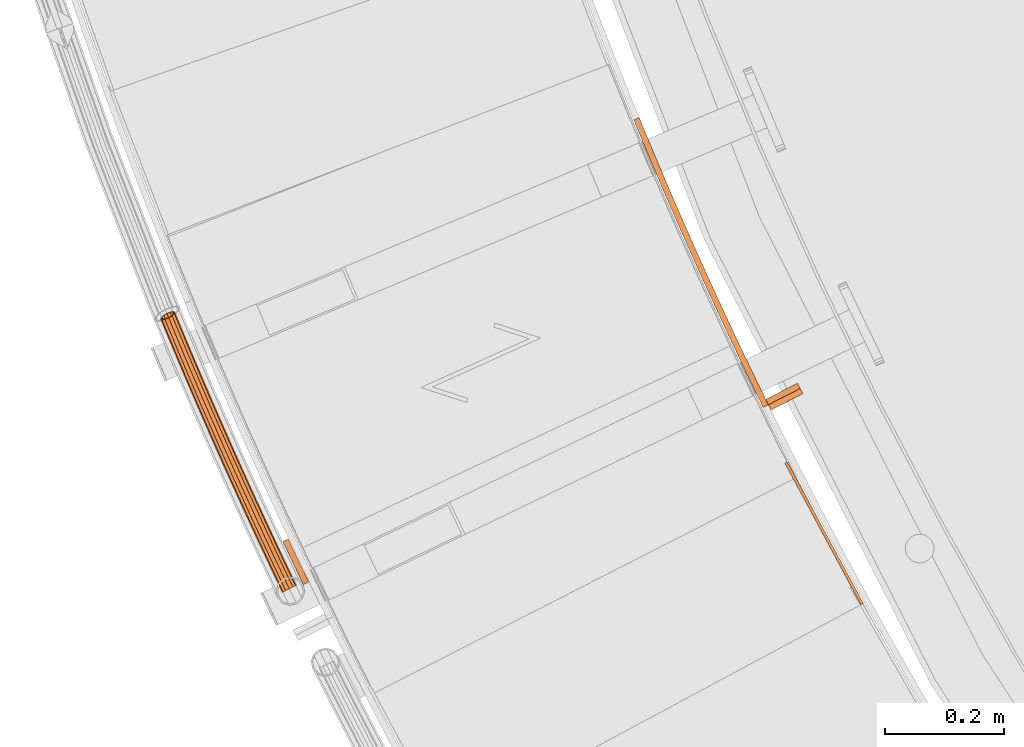
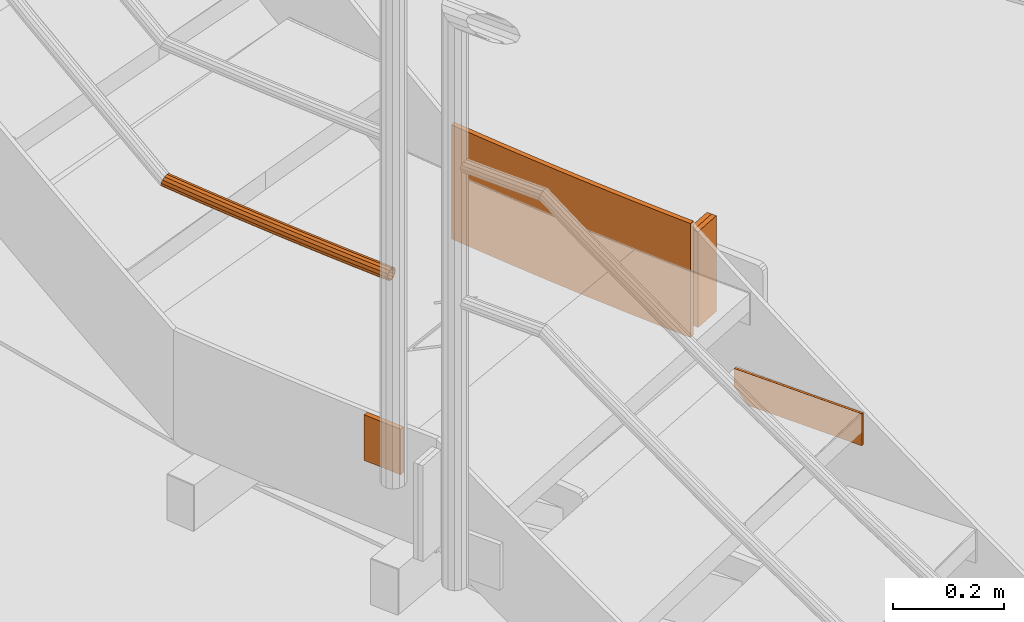
# One storey, part 49 of 126: 6 proxies.
"""IFC2X3 building model written with IfcOpenShell, lengths in millimetres."""

from ifc_helpers import new_model, si_unit, origin, origin_with_axes, place, context, project, spatial, faceted_brep, material, element, save


model = new_model("IFC2X3")

# Units and contexts
context_of_model_1 = context(None, 3, precision=0.1, world=origin())
context_of_model_2 = context(None, 3, precision=0.1, world=origin())
ifc_project = project(units=[si_unit("LENGTHUNIT", "METRE", prefix="MILLI"), si_unit("AREAUNIT", "SQUARE_METRE", prefix="CENTI"), si_unit("VOLUMEUNIT", "CUBIC_METRE", prefix="CENTI"), si_unit("MASSUNIT", "GRAM", prefix="KILO")], contexts=[context_of_model_1, context_of_model_2])

# Site, building, storey
site_placement = place(None, origin_with_axes())
site = spatial("IfcSite", under=ifc_project, at=site_placement, CompositionType="ELEMENT")
building_placement = place(site_placement, origin_with_axes())
building = spatial("IfcBuilding", under=site, at=building_placement, CompositionType="ELEMENT")
storey_placement = place(building_placement, origin_with_axes())
storey = spatial("IfcBuildingStorey", under=building, at=storey_placement, CompositionType="ELEMENT")

# Proxies
ifc_material = material(Name="S235JRG2")
proxy_1_placement = place(storey_placement, origin_with_axes())
element("IfcBuildingElementProxy", 1, at=proxy_1_placement, inside=storey, material=ifc_material, context=context_of_model_2, shape_type="Brep", body=[
    faceted_brep([(972.6505, 4145.1036, 2527.45), (977.0555, 4147.4692, 2527.45), (977.0555, 4147.4692, 2597.45), (972.6505, 4145.1036, 2597.45), (844.9091, 4382.9736, 2597.45), (849.3141, 4385.3392, 2597.45), (849.3141, 4385.3392, 2557.45), (844.9091, 4382.9736, 2557.45), (859.1026, 4356.5436, 2527.45), (863.5076, 4358.9092, 2527.45)], [[[0, 1, 2, 3]], [[4, 5, 6, 7]], [[0, 8, 9, 1]], [[1, 9, 6, 5, 2]], [[2, 5, 4, 3]], [[0, 3, 4, 7, 8]], [[6, 9, 8, 7]]]),
])
proxy_2_placement = place(storey_placement, origin_with_axes())
element("IfcBuildingElementProxy", 2, at=proxy_2_placement, inside=storey, material=ifc_material, context=context_of_model_2, shape_type="Brep", body=[
    faceted_brep([(804.2181, 4485.1622, 2621.25), (813.2023, 4489.5538, 2621.25), (817.3795, 4481.0833, 2621.25), (808.4725, 4476.5352, 2621.25), (813.2023, 4489.5538, 2871.25), (817.3795, 4481.0833, 2871.25), (804.2181, 4485.1622, 2871.25), (808.4725, 4476.5352, 2871.25), (779.8204, 4535.5184, 2621.25), (788.835, 4539.8472, 2621.25), (788.835, 4539.8472, 2871.25), (779.8204, 4535.5184, 2871.25), (755.7747, 4586.0437, 2621.25), (764.8193, 4590.3095, 2621.25), (764.8193, 4590.3095, 2871.25), (755.7747, 4586.0437, 2871.25), (732.0823, 4636.7356, 2621.25), (741.1564, 4640.9382, 2621.25), (741.1564, 4640.9382, 2871.25), (732.0823, 4636.7356, 2871.25), (708.7442, 4687.5917, 2621.25), (717.8475, 4691.7308, 2621.25), (717.8475, 4691.7308, 2871.25), (708.7442, 4687.5917, 2871.25), (685.7617, 4738.6093, 2621.25), (694.8936, 4742.6848, 2621.25), (694.8936, 4742.6848, 2871.25), (685.7617, 4738.6093, 2871.25), (663.1358, 4789.7862, 2621.25), (672.2959, 4793.7978, 2621.25), (672.2959, 4793.7978, 2871.25), (663.1358, 4789.7862, 2871.25), (640.8676, 4841.1197, 2621.25), (650.0555, 4845.0673, 2621.25), (650.0555, 4845.0673, 2871.25), (640.8676, 4841.1197, 2871.25), (618.9583, 4892.6073, 2621.25), (628.1735, 4896.4907, 2621.25), (628.1735, 4896.4907, 2871.25), (618.9583, 4892.6073, 2871.25), (597.4088, 4944.2467, 2621.25), (606.6509, 4948.0657, 2621.25), (606.6509, 4948.0657, 2871.25), (597.4088, 4944.2467, 2871.25), (591.3227, 4959.1223, 2621.25), (600.2601, 4963.686, 2621.25), (600.2601, 4963.686, 2871.25), (591.3227, 4959.1223, 2871.25)], [[[0, 1, 2, 3]], [[1, 4, 5, 2]], [[4, 6, 7, 5]], [[0, 3, 7, 6]], [[0, 8, 9, 1]], [[1, 9, 10, 4]], [[4, 10, 11, 6]], [[6, 11, 8, 0]], [[8, 12, 13, 9]], [[9, 13, 14, 10]], [[10, 14, 15, 11]], [[11, 15, 12, 8]], [[12, 16, 17, 13]], [[13, 17, 18, 14]], [[14, 18, 19, 15]], [[15, 19, 16, 12]], [[16, 20, 21, 17]], [[17, 21, 22, 18]], [[18, 22, 23, 19]], [[19, 23, 20, 16]], [[20, 24, 25, 21]], [[21, 25, 26, 22]], [[22, 26, 27, 23]], [[23, 27, 24, 20]], [[24, 28, 29, 25]], [[25, 29, 30, 26]], [[26, 30, 31, 27]], [[27, 31, 28, 24]], [[28, 32, 33, 29]], [[29, 33, 34, 30]], [[30, 34, 35, 31]], [[31, 35, 32, 28]], [[32, 36, 37, 33]], [[33, 37, 38, 34]], [[34, 38, 39, 35]], [[35, 39, 36, 32]], [[36, 40, 41, 37]], [[37, 41, 42, 38]], [[38, 42, 43, 39]], [[39, 43, 40, 36]], [[40, 44, 45, 41]], [[41, 45, 46, 42]], [[42, 46, 47, 43]], [[40, 43, 47, 44]], [[2, 5, 7, 3]], [[44, 47, 46, 45]]]),
])
proxy_3_placement = place(storey_placement, origin_with_axes())
element("IfcBuildingElementProxy", 3, at=proxy_3_placement, inside=storey, material=ifc_material, context=context_of_model_2, shape_type="Brep", body=[
    faceted_brep([(817.3796, 4481.0831, 2851.25), (812.8319, 4489.9892, 2851.25), (812.8319, 4489.9892, 2641.25), (817.3796, 4481.0831, 2641.25), (866.2685, 4517.2753, 2851.25), (870.8162, 4508.3692, 2851.25), (870.8162, 4508.3692, 2641.25), (866.2685, 4517.2753, 2641.25)], [[[0, 1, 2, 3]], [[4, 5, 6, 7]], [[0, 3, 6, 5]], [[1, 4, 7, 2]], [[0, 5, 4, 1]], [[2, 7, 6, 3]]]),
])
proxy_4_placement = place(storey_placement, origin_with_axes())
element("IfcBuildingElementProxy", 4, at=proxy_4_placement, inside=storey, material=ifc_material, context=context_of_model_2, shape_type="Brep", body=[
    faceted_brep([(821.9273, 4472.177, 2851.25), (817.3796, 4481.0831, 2851.25), (817.3796, 4481.0831, 2641.25), (821.9273, 4472.177, 2641.25), (870.8162, 4508.3692, 2851.25), (875.3639, 4499.4631, 2851.25), (875.3639, 4499.4631, 2641.25), (870.8162, 4508.3692, 2641.25)], [[[0, 1, 2, 3]], [[4, 5, 6, 7]], [[0, 3, 6, 5]], [[1, 4, 7, 2]], [[0, 5, 4, 1]], [[2, 7, 6, 3]]]),
])
proxy_5_placement = place(storey_placement, origin_with_axes())
element("IfcBuildingElementProxy", 5, at=proxy_5_placement, inside=storey, material=ifc_material, context=context_of_model_2, shape_type="Brep", body=[
    faceted_brep([(-4.3297, 4176.1625, 3224.2551), (-2.7039, 4176.9397, 3217.5301), (2.3279, 4166.4608, 3217.5301), (0.7226, 4165.6411, 3224.2551), (1.7377, 4179.063, 3212.607), (6.7137, 4168.7004, 3212.607), (7.805, 4181.9635, 3210.8051), (12.7049, 4171.7596, 3210.8051), (13.8724, 4184.864, 3212.607), (18.696, 4174.8188, 3212.607), (18.314, 4186.9873, 3217.5301), (23.0818, 4177.0583, 3217.5301), (19.9398, 4187.7645, 3224.2551), (24.6872, 4177.878, 3224.2551), (18.314, 4186.9873, 3230.9801), (23.0818, 4177.0583, 3230.9801), (13.8724, 4184.864, 3235.9031), (18.696, 4174.8188, 3235.9031), (7.805, 4181.9635, 3237.7051), (12.7049, 4171.7596, 3237.7051), (1.7377, 4179.063, 3235.9031), (6.7137, 4168.7004, 3235.9031), (-2.7039, 4176.9397, 3230.9801), (2.3279, 4166.4608, 3230.9801), (-2.5253, 4177.0251, 3224.2551), (-1.1413, 4177.6867, 3229.9801), (3.871, 4167.2488, 3229.9801), (2.5044, 4166.5509, 3224.2551), (2.6399, 4179.4943, 3234.1711), (7.6046, 4169.1553, 3234.1711), (7.805, 4181.9635, 3235.7051), (12.7049, 4171.7596, 3235.7051), (12.9702, 4184.4327, 3234.1711), (17.8052, 4174.3639, 3234.1711), (16.7513, 4186.2403, 3229.9801), (21.5388, 4176.2704, 3229.9801), (18.1353, 4186.9019, 3224.2551), (22.9054, 4176.9682, 3224.2551), (16.7513, 4186.2403, 3218.5301), (21.5388, 4176.2704, 3218.5301), (12.9702, 4184.4327, 3214.3391), (17.8052, 4174.3639, 3214.3391), (7.805, 4181.9635, 3212.8051), (12.7049, 4171.7596, 3212.8051), (2.6399, 4179.4943, 3214.3391), (7.6046, 4169.1553, 3214.3391), (-1.1413, 4177.6867, 3218.5301), (3.871, 4167.2488, 3218.5301), (-17.646, 4204.1436, 3224.2551), (-16.0176, 4204.9151, 3217.5301), (-11.5686, 4207.0229, 3212.607), (-5.4911, 4209.9022, 3210.8051), (0.5863, 4212.7815, 3212.607), (5.0353, 4214.8893, 3217.5301), (6.6638, 4215.6608, 3224.2551), (5.0353, 4214.8893, 3230.9801), (0.5863, 4212.7815, 3235.9031), (-5.4911, 4209.9022, 3237.7051), (-11.5686, 4207.0229, 3235.9031), (-16.0176, 4204.9151, 3230.9801), (-15.8386, 4204.9999, 3224.2551), (-14.4523, 4205.6567, 3229.9801), (-10.6649, 4207.4511, 3234.1711), (-5.4911, 4209.9022, 3235.7051), (-0.3174, 4212.3534, 3234.1711), (3.4701, 4214.1477, 3229.9801), (4.8564, 4214.8045, 3224.2551), (3.4701, 4214.1477, 3218.5301), (-0.3174, 4212.3534, 3214.3391), (-5.4911, 4209.9022, 3212.8051), (-10.6649, 4207.4511, 3214.3391), (-14.4523, 4205.6567, 3218.5301), (-30.8646, 4232.171, 3224.2551), (-29.2335, 4232.9369, 3217.5301), (-24.7772, 4235.0291, 3212.607), (-18.6897, 4237.8872, 3210.8051), (-12.6022, 4240.7452, 3212.607), (-8.1459, 4242.8375, 3217.5301), (-6.5148, 4243.6033, 3224.2551), (-8.1459, 4242.8375, 3230.9801), (-12.6022, 4240.7452, 3235.9031), (-18.6897, 4237.8872, 3237.7051), (-24.7772, 4235.0291, 3235.9031), (-29.2335, 4232.9369, 3230.9801), (-29.0542, 4233.021, 3224.2551), (-27.6656, 4233.673, 3229.9801), (-23.872, 4235.4541, 3234.1711), (-18.6897, 4237.8872, 3235.7051), (-13.5074, 4240.3202, 3234.1711), (-9.7137, 4242.1014, 3229.9801), (-8.3252, 4242.7533, 3224.2551), (-9.7137, 4242.1014, 3218.5301), (-13.5074, 4240.3202, 3214.3391), (-18.6897, 4237.8872, 3212.8051), (-23.872, 4235.4541, 3214.3391), (-27.6656, 4233.673, 3218.5301), (-43.9853, 4260.2444, 3224.2551), (-42.3515, 4261.0046, 3217.5301), (-37.8879, 4263.0812, 3212.607), (-31.7905, 4265.918, 3210.8051), (-25.6931, 4268.7548, 3212.607), (-21.2295, 4270.8315, 3217.5301), (-19.5957, 4271.5916, 3224.2551), (-21.2295, 4270.8315, 3230.9801), (-25.6931, 4268.7548, 3235.9031), (-31.7905, 4265.918, 3237.7051), (-37.8879, 4263.0812, 3235.9031), (-42.3515, 4261.0046, 3230.9801), (-42.1719, 4261.0881, 3224.2551), (-40.7811, 4261.7352, 3229.9801), (-36.9812, 4263.5031, 3234.1711), (-31.7905, 4265.918, 3235.7051), (-26.5998, 4268.333, 3234.1711), (-22.7999, 4270.1009, 3229.9801), (-21.409, 4270.7479, 3224.2551), (-22.7999, 4270.1009, 3218.5301), (-26.5998, 4268.333, 3214.3391), (-31.7905, 4265.918, 3212.8051), (-36.9812, 4263.5031, 3214.3391), (-40.7811, 4261.7352, 3218.5301), (-57.0079, 4288.3635, 3224.2551), (-55.3715, 4289.1179, 3217.5301), (-50.9006, 4291.1789, 3212.607), (-44.7934, 4293.9944, 3210.8051), (-38.6861, 4296.8099, 3212.607), (-34.2152, 4298.871, 3217.5301), (-32.5788, 4299.6254, 3224.2551), (-34.2152, 4298.871, 3230.9801), (-38.6861, 4296.8099, 3235.9031), (-44.7934, 4293.9944, 3237.7051), (-50.9006, 4291.1789, 3235.9031), (-55.3715, 4289.1179, 3230.9801), (-55.1916, 4289.2008, 3224.2551), (-53.7985, 4289.843, 3229.9801), (-49.9925, 4291.5976, 3234.1711), (-44.7934, 4293.9944, 3235.7051), (-39.5942, 4296.3913, 3234.1711), (-35.7882, 4298.1459, 3229.9801), (-34.3951, 4298.7881, 3224.2551), (-35.7882, 4298.1459, 3218.5301), (-39.5942, 4296.3913, 3214.3391), (-44.7934, 4293.9944, 3212.8051), (-49.9925, 4291.5976, 3214.3391), (-53.7985, 4289.843, 3218.5301), (-69.9323, 4316.5278, 3224.2551), (-68.2932, 4317.2764, 3217.5301), (-63.8152, 4319.3219, 3212.607), (-57.6981, 4322.1161, 3210.8051), (-51.5811, 4324.9102, 3212.607), (-47.1031, 4326.9557, 3217.5301), (-45.464, 4327.7044, 3224.2551), (-47.1031, 4326.9557, 3230.9801), (-51.5811, 4324.9102, 3235.9031), (-57.6981, 4322.1161, 3237.7051), (-63.8152, 4319.3219, 3235.9031), (-68.2932, 4317.2764, 3230.9801), (-68.1131, 4317.3587, 3224.2551), (-66.7177, 4317.9961, 3229.9801), (-62.9056, 4319.7374, 3234.1711), (-57.6981, 4322.1161, 3235.7051), (-52.4907, 4324.4947, 3234.1711), (-48.6785, 4326.236, 3229.9801), (-47.2832, 4326.8734, 3224.2551), (-48.6785, 4326.236, 3218.5301), (-52.4907, 4324.4947, 3214.3391), (-57.6981, 4322.1161, 3212.8051), (-62.9056, 4319.7374, 3214.3391), (-66.7177, 4317.9961, 3218.5301), (-82.7582, 4344.737, 3224.2551), (-81.1166, 4345.48, 3217.5301), (-76.6315, 4347.5098, 3212.607), (-70.5047, 4350.2826, 3210.8051), (-64.3779, 4353.0554, 3212.607), (-59.8928, 4355.0852, 3217.5301), (-58.2511, 4355.8281, 3224.2551), (-59.8928, 4355.0852, 3230.9801), (-64.3779, 4353.0554, 3235.9031), (-70.5047, 4350.2826, 3237.7051), (-76.6315, 4347.5098, 3235.9031), (-81.1166, 4345.48, 3230.9801), (-80.9361, 4345.5616, 3224.2551), (-79.5386, 4346.1941, 3229.9801), (-75.7204, 4347.9221, 3234.1711), (-70.5047, 4350.2826, 3235.7051), (-65.2889, 4352.643, 3234.1711), (-61.4708, 4354.371, 3229.9801), (-60.0732, 4355.0035, 3224.2551), (-61.4708, 4354.371, 3218.5301), (-65.2889, 4352.643, 3214.3391), (-70.5047, 4350.2826, 3212.8051), (-75.7204, 4347.9221, 3214.3391), (-79.5386, 4346.1941, 3218.5301), (-95.4857, 4372.9908, 3224.2551), (-93.8414, 4373.7281, 3217.5301), (-89.3492, 4375.7422, 3212.607), (-83.2128, 4378.4936, 3210.8051), (-77.0764, 4381.245, 3212.607), (-72.5842, 4383.2591, 3217.5301), (-70.94, 4383.9964, 3224.2551), (-72.5842, 4383.2591, 3230.9801), (-77.0764, 4381.245, 3235.9031), (-83.2128, 4378.4936, 3237.7051), (-89.3492, 4375.7422, 3235.9031), (-93.8414, 4373.7281, 3230.9801), (-93.6607, 4373.8091, 3224.2551), (-92.261, 4374.4367, 3229.9801), (-88.4368, 4376.1514, 3234.1711), (-83.2128, 4378.4936, 3235.7051), (-77.9889, 4380.8359, 3234.1711), (-74.1647, 4382.5505, 3229.9801), (-72.7649, 4383.1781, 3224.2551), (-74.1647, 4382.5505, 3218.5301), (-77.9889, 4380.8359, 3214.3391), (-83.2128, 4378.4936, 3212.8051), (-88.4368, 4376.1514, 3214.3391), (-92.261, 4374.4367, 3218.5301), (-108.1144, 4401.2889, 3224.2551), (-106.4676, 4402.0204, 3217.5301), (-101.9684, 4404.0189, 3212.607), (-95.8224, 4406.7488, 3210.8051), (-89.6764, 4409.4788, 3212.607), (-85.1773, 4411.4772, 3217.5301), (-83.5304, 4412.2087, 3224.2551), (-85.1773, 4411.4772, 3230.9801), (-89.6764, 4409.4788, 3235.9031), (-95.8224, 4406.7488, 3237.7051), (-101.9684, 4404.0189, 3235.9031), (-106.4676, 4402.0204, 3230.9801), (-106.2866, 4402.1008, 3224.2551), (-104.8847, 4402.7235, 3229.9801), (-101.0545, 4404.4248, 3234.1711), (-95.8224, 4406.7488, 3235.7051), (-90.5903, 4409.0728, 3234.1711), (-86.7602, 4410.7741, 3229.9801), (-85.3582, 4411.3968, 3224.2551), (-86.7602, 4410.7741, 3218.5301), (-90.5903, 4409.0728, 3214.3391), (-95.8224, 4406.7488, 3212.8051), (-101.0545, 4404.4248, 3214.3391), (-104.8847, 4402.7235, 3218.5301), (-120.6443, 4429.631, 3224.2551), (-118.9949, 4430.3567, 3217.5301), (-114.4888, 4432.3394, 3212.607), (-108.3333, 4435.0479, 3210.8051), (-102.1778, 4437.7564, 3212.607), (-97.6717, 4439.7391, 3217.5301), (-96.0224, 4440.4649, 3224.2551), (-97.6717, 4439.7391, 3230.9801), (-102.1778, 4437.7564, 3235.9031), (-108.3333, 4435.0479, 3237.7051), (-114.4888, 4432.3394, 3235.9031), (-118.9949, 4430.3567, 3230.9801), (-118.8136, 4430.4364, 3224.2551), (-117.4095, 4431.0543, 3229.9801), (-113.5735, 4432.7422, 3234.1711), (-108.3333, 4435.0479, 3235.7051), (-103.0931, 4437.3536, 3234.1711), (-99.2571, 4439.0415, 3229.9801), (-97.853, 4439.6594, 3224.2551), (-99.2571, 4439.0415, 3218.5301), (-103.0931, 4437.3536, 3214.3391), (-108.3333, 4435.0479, 3212.8051), (-113.5735, 4432.7422, 3214.3391), (-117.4095, 4431.0543, 3218.5301), (-133.0751, 4458.0165, 3224.2551), (-131.4233, 4458.7365, 3217.5301), (-126.9102, 4460.7035, 3212.607), (-120.7453, 4463.3905, 3210.8051), (-114.5804, 4466.0774, 3212.607), (-110.0674, 4468.0444, 3217.5301), (-108.4155, 4468.7644, 3224.2551), (-110.0674, 4468.0444, 3230.9801), (-114.5804, 4466.0774, 3235.9031), (-120.7453, 4463.3905, 3237.7051), (-126.9102, 4460.7035, 3235.9031), (-131.4233, 4458.7365, 3230.9801), (-131.2417, 4458.8156, 3224.2551), (-129.8355, 4459.4285, 3229.9801), (-125.9935, 4461.103, 3234.1711), (-120.7453, 4463.3905, 3235.7051), (-115.4972, 4465.6779, 3234.1711), (-111.6552, 4467.3524, 3229.9801), (-110.249, 4467.9653, 3224.2551), (-111.6552, 4467.3524, 3218.5301), (-115.4972, 4465.6779, 3214.3391), (-120.7453, 4463.3905, 3212.8051), (-125.9935, 4461.103, 3214.3391), (-129.8355, 4459.4285, 3218.5301), (-145.4068, 4486.4453, 3224.2551), (-143.7524, 4487.1595, 3217.5301), (-139.2326, 4489.1108, 3212.607), (-133.0584, 4491.7762, 3210.8051), (-126.8841, 4494.4416, 3212.607), (-122.3643, 4496.3929, 3217.5301), (-120.7099, 4497.1071, 3224.2551), (-122.3643, 4496.3929, 3230.9801), (-126.8841, 4494.4416, 3235.9031), (-133.0584, 4491.7762, 3237.7051), (-139.2326, 4489.1108, 3235.9031), (-143.7524, 4487.1595, 3230.9801), (-143.5706, 4487.238, 3224.2551), (-142.1623, 4487.846, 3229.9801), (-138.3145, 4489.5071, 3234.1711), (-133.0584, 4491.7762, 3235.7051), (-127.8022, 4494.0453, 3234.1711), (-123.9545, 4495.7064, 3229.9801), (-122.5461, 4496.3144, 3224.2551), (-123.9545, 4495.7064, 3218.5301), (-127.8022, 4494.0453, 3214.3391), (-133.0584, 4491.7762, 3212.8051), (-138.3145, 4489.5071, 3214.3391), (-142.1623, 4487.846, 3218.5301), (-157.6392, 4514.917, 3224.2551), (-155.9824, 4515.6254, 3217.5301), (-151.4557, 4517.5609, 3212.607), (-145.2722, 4520.2047, 3210.8051), (-139.0887, 4522.8486, 3212.607), (-134.5621, 4524.784, 3217.5301), (-132.9052, 4525.4925, 3224.2551), (-134.5621, 4524.784, 3230.9801), (-139.0887, 4522.8486, 3235.9031), (-145.2722, 4520.2047, 3237.7051), (-151.4557, 4517.5609, 3235.9031), (-155.9824, 4515.6254, 3230.9801), (-155.8003, 4515.7033, 3224.2551), (-154.3898, 4516.3063, 3229.9801), (-150.5362, 4517.954, 3234.1711), (-145.2722, 4520.2047, 3235.7051), (-140.0082, 4522.4554, 3234.1711), (-136.1547, 4524.1031, 3229.9801), (-134.7442, 4524.7062, 3224.2551), (-136.1547, 4524.1031, 3218.5301), (-140.0082, 4522.4554, 3214.3391), (-145.2722, 4520.2047, 3212.8051), (-150.5362, 4517.954, 3214.3391), (-154.3898, 4516.3063, 3218.5301), (-169.7722, 4543.4312, 3224.2551), (-168.1128, 4544.1338, 3217.5301), (-163.5795, 4546.0534, 3212.607), (-157.3868, 4548.6757, 3210.8051), (-151.1941, 4551.298, 3212.607), (-146.6607, 4553.2176, 3217.5301), (-145.0014, 4553.9202, 3224.2551), (-146.6607, 4553.2176, 3230.9801), (-151.1941, 4551.298, 3235.9031), (-157.3868, 4548.6757, 3237.7051), (-163.5795, 4546.0534, 3235.9031), (-168.1128, 4544.1338, 3230.9801), (-167.9305, 4544.211, 3224.2551), (-166.5179, 4544.8092, 3229.9801), (-162.6586, 4546.4434, 3234.1711), (-157.3868, 4548.6757, 3235.7051), (-152.1149, 4550.9081, 3234.1711), (-148.2557, 4552.5422, 3229.9801), (-146.8431, 4553.1404, 3224.2551), (-148.2557, 4552.5422, 3218.5301), (-152.1149, 4550.9081, 3214.3391), (-157.3868, 4548.6757, 3212.8051), (-162.6586, 4546.4434, 3214.3391), (-166.5179, 4544.8092, 3218.5301), (-181.8055, 4571.9875, 3224.2551), (-180.1437, 4572.6844, 3217.5301), (-175.6037, 4574.5882, 3212.607), (-169.4019, 4577.1888, 3210.8051), (-163.2001, 4579.7895, 3212.607), (-158.66, 4581.6932, 3217.5301), (-156.9982, 4582.3901, 3224.2551), (-158.66, 4581.6932, 3230.9801), (-163.2001, 4579.7895, 3235.9031), (-169.4019, 4577.1888, 3237.7051), (-175.6037, 4574.5882, 3235.9031), (-180.1437, 4572.6844, 3230.9801), (-179.9611, 4572.761, 3224.2551), (-178.5464, 4573.3542, 3229.9801), (-174.6815, 4574.9749, 3234.1711), (-169.4019, 4577.1888, 3235.7051), (-164.1223, 4579.4027, 3234.1711), (-160.2573, 4581.0234, 3229.9801), (-158.8426, 4581.6167, 3224.2551), (-160.2573, 4581.0234, 3218.5301), (-164.1223, 4579.4027, 3214.3391), (-169.4019, 4577.1888, 3212.8051), (-174.6815, 4574.9749, 3214.3391), (-178.5464, 4573.3542, 3218.5301), (-193.7391, 4600.5857, 3224.2551), (-192.0749, 4601.2768, 3217.5301), (-187.5282, 4603.1647, 3212.607), (-181.3174, 4605.7437, 3210.8051), (-175.1065, 4608.3227, 3212.607), (-170.5598, 4610.2106, 3217.5301), (-168.8957, 4610.9016, 3224.2551), (-170.5598, 4610.2106, 3230.9801), (-175.1065, 4608.3227, 3235.9031), (-181.3174, 4605.7437, 3237.7051), (-187.5282, 4603.1647, 3235.9031), (-192.0749, 4601.2768, 3230.9801), (-191.892, 4601.3527, 3224.2551), (-190.4752, 4601.941, 3229.9801), (-186.6047, 4603.5482, 3234.1711), (-181.3174, 4605.7437, 3235.7051), (-176.0301, 4607.9392, 3234.1711), (-172.1595, 4609.5464, 3229.9801), (-170.7427, 4610.1346, 3224.2551), (-172.1595, 4609.5464, 3218.5301), (-176.0301, 4607.9392, 3214.3391), (-181.3174, 4605.7437, 3212.8051), (-186.6047, 4603.5482, 3214.3391), (-190.4752, 4601.941, 3218.5301), (-203.6844, 4624.6552, 3224.2551), (-202.8892, 4627.4496, 3217.5301), (-199.0871, 4631.1394, 3212.607), (-195.5034, 4633.3654, 3211.4918), (-193.1331, 4634.34, 3210.8051), (-186.9133, 4636.8973, 3212.607), (-185.302, 4637.5597, 3214.3492), (-182.0745, 4638.0781, 3217.5301), (-179.6495, 4636.928, 3224.2551), (-180.4447, 4634.1337, 3230.9801), (-184.2468, 4630.4438, 3235.9031), (-190.0371, 4626.8472, 3237.7051), (-196.2642, 4624.3074, 3235.9031), (-201.2594, 4623.5051, 3230.9801), (-201.8974, 4625.5677, 3224.2551), (-199.833, 4624.5886, 3229.9801), (-195.5806, 4625.2716, 3234.1711), (-190.2795, 4627.4337, 3235.7051), (-185.3502, 4630.4955, 3234.1711), (-182.1134, 4633.6367, 3229.9801), (-181.4365, 4636.0155, 3224.2551), (-183.5009, 4636.9946, 3218.5301), (-187.7533, 4636.3116, 3214.3391), (-193.0544, 4634.1495, 3212.8051), (-197.9837, 4631.0877, 3214.3391), (-201.2205, 4627.9465, 3218.5301), (-193.2954, 4634.7367, 3210.8051), (-187.0684, 4637.2765, 3212.607)], [[[0, 1, 2, 3]], [[1, 4, 5, 2]], [[4, 6, 7, 5]], [[6, 8, 9, 7]], [[8, 10, 11, 9]], [[10, 12, 13, 11]], [[12, 14, 15, 13]], [[14, 16, 17, 15]], [[16, 18, 19, 17]], [[18, 20, 21, 19]], [[20, 22, 23, 21]], [[0, 3, 23, 22]], [[24, 25, 26, 27]], [[25, 28, 29, 26]], [[28, 30, 31, 29]], [[30, 32, 33, 31]], [[32, 34, 35, 33]], [[34, 36, 37, 35]], [[36, 38, 39, 37]], [[38, 40, 41, 39]], [[40, 42, 43, 41]], [[42, 44, 45, 43]], [[44, 46, 47, 45]], [[24, 27, 47, 46]], [[0, 48, 49, 1]], [[1, 49, 50, 4]], [[4, 50, 51, 6]], [[6, 51, 52, 8]], [[8, 52, 53, 10]], [[10, 53, 54, 12]], [[12, 54, 55, 14]], [[14, 55, 56, 16]], [[16, 56, 57, 18]], [[18, 57, 58, 20]], [[20, 58, 59, 22]], [[22, 59, 48, 0]], [[24, 60, 61, 25]], [[25, 61, 62, 28]], [[28, 62, 63, 30]], [[30, 63, 64, 32]], [[32, 64, 65, 34]], [[34, 65, 66, 36]], [[36, 66, 67, 38]], [[38, 67, 68, 40]], [[40, 68, 69, 42]], [[42, 69, 70, 44]], [[44, 70, 71, 46]], [[46, 71, 60, 24]], [[48, 72, 73, 49]], [[49, 73, 74, 50]], [[50, 74, 75, 51]], [[51, 75, 76, 52]], [[52, 76, 77, 53]], [[53, 77, 78, 54]], [[54, 78, 79, 55]], [[55, 79, 80, 56]], [[56, 80, 81, 57]], [[57, 81, 82, 58]], [[58, 82, 83, 59]], [[59, 83, 72, 48]], [[60, 84, 85, 61]], [[61, 85, 86, 62]], [[62, 86, 87, 63]], [[63, 87, 88, 64]], [[64, 88, 89, 65]], [[65, 89, 90, 66]], [[66, 90, 91, 67]], [[67, 91, 92, 68]], [[68, 92, 93, 69]], [[69, 93, 94, 70]], [[70, 94, 95, 71]], [[71, 95, 84, 60]], [[72, 96, 97, 73]], [[73, 97, 98, 74]], [[74, 98, 99, 75]], [[75, 99, 100, 76]], [[76, 100, 101, 77]], [[77, 101, 102, 78]], [[78, 102, 103, 79]], [[79, 103, 104, 80]], [[80, 104, 105, 81]], [[81, 105, 106, 82]], [[82, 106, 107, 83]], [[83, 107, 96, 72]], [[84, 108, 109, 85]], [[85, 109, 110, 86]], [[86, 110, 111, 87]], [[87, 111, 112, 88]], [[88, 112, 113, 89]], [[89, 113, 114, 90]], [[90, 114, 115, 91]], [[91, 115, 116, 92]], [[92, 116, 117, 93]], [[93, 117, 118, 94]], [[94, 118, 119, 95]], [[95, 119, 108, 84]], [[96, 120, 121, 97]], [[97, 121, 122, 98]], [[98, 122, 123, 99]], [[99, 123, 124, 100]], [[100, 124, 125, 101]], [[101, 125, 126, 102]], [[102, 126, 127, 103]], [[103, 127, 128, 104]], [[104, 128, 129, 105]], [[105, 129, 130, 106]], [[106, 130, 131, 107]], [[107, 131, 120, 96]], [[108, 132, 133, 109]], [[109, 133, 134, 110]], [[110, 134, 135, 111]], [[111, 135, 136, 112]], [[112, 136, 137, 113]], [[113, 137, 138, 114]], [[114, 138, 139, 115]], [[115, 139, 140, 116]], [[116, 140, 141, 117]], [[117, 141, 142, 118]], [[118, 142, 143, 119]], [[119, 143, 132, 108]], [[120, 144, 145, 121]], [[121, 145, 146, 122]], [[122, 146, 147, 123]], [[123, 147, 148, 124]], [[124, 148, 149, 125]], [[125, 149, 150, 126]], [[126, 150, 151, 127]], [[127, 151, 152, 128]], [[128, 152, 153, 129]], [[129, 153, 154, 130]], [[130, 154, 155, 131]], [[131, 155, 144, 120]], [[132, 156, 157, 133]], [[133, 157, 158, 134]], [[134, 158, 159, 135]], [[135, 159, 160, 136]], [[136, 160, 161, 137]], [[137, 161, 162, 138]], [[138, 162, 163, 139]], [[139, 163, 164, 140]], [[140, 164, 165, 141]], [[141, 165, 166, 142]], [[142, 166, 167, 143]], [[143, 167, 156, 132]], [[144, 168, 169, 145]], [[145, 169, 170, 146]], [[146, 170, 171, 147]], [[147, 171, 172, 148]], [[148, 172, 173, 149]], [[149, 173, 174, 150]], [[150, 174, 175, 151]], [[151, 175, 176, 152]], [[152, 176, 177, 153]], [[153, 177, 178, 154]], [[154, 178, 179, 155]], [[155, 179, 168, 144]], [[156, 180, 181, 157]], [[157, 181, 182, 158]], [[158, 182, 183, 159]], [[159, 183, 184, 160]], [[160, 184, 185, 161]], [[161, 185, 186, 162]], [[162, 186, 187, 163]], [[163, 187, 188, 164]], [[164, 188, 189, 165]], [[165, 189, 190, 166]], [[166, 190, 191, 167]], [[167, 191, 180, 156]], [[168, 192, 193, 169]], [[169, 193, 194, 170]], [[170, 194, 195, 171]], [[171, 195, 196, 172]], [[172, 196, 197, 173]], [[173, 197, 198, 174]], [[174, 198, 199, 175]], [[175, 199, 200, 176]], [[176, 200, 201, 177]], [[177, 201, 202, 178]], [[178, 202, 203, 179]], [[179, 203, 192, 168]], [[180, 204, 205, 181]], [[181, 205, 206, 182]], [[182, 206, 207, 183]], [[183, 207, 208, 184]], [[184, 208, 209, 185]], [[185, 209, 210, 186]], [[186, 210, 211, 187]], [[187, 211, 212, 188]], [[188, 212, 213, 189]], [[189, 213, 214, 190]], [[190, 214, 215, 191]], [[191, 215, 204, 180]], [[192, 216, 217, 193]], [[193, 217, 218, 194]], [[194, 218, 219, 195]], [[195, 219, 220, 196]], [[196, 220, 221, 197]], [[197, 221, 222, 198]], [[198, 222, 223, 199]], [[199, 223, 224, 200]], [[200, 224, 225, 201]], [[201, 225, 226, 202]], [[202, 226, 227, 203]], [[203, 227, 216, 192]], [[204, 228, 229, 205]], [[205, 229, 230, 206]], [[206, 230, 231, 207]], [[207, 231, 232, 208]], [[208, 232, 233, 209]], [[209, 233, 234, 210]], [[210, 234, 235, 211]], [[211, 235, 236, 212]], [[212, 236, 237, 213]], [[213, 237, 238, 214]], [[214, 238, 239, 215]], [[215, 239, 228, 204]], [[216, 240, 241, 217]], [[217, 241, 242, 218]], [[218, 242, 243, 219]], [[219, 243, 244, 220]], [[220, 244, 245, 221]], [[221, 245, 246, 222]], [[222, 246, 247, 223]], [[223, 247, 248, 224]], [[224, 248, 249, 225]], [[225, 249, 250, 226]], [[226, 250, 251, 227]], [[227, 251, 240, 216]], [[228, 252, 253, 229]], [[229, 253, 254, 230]], [[230, 254, 255, 231]], [[231, 255, 256, 232]], [[232, 256, 257, 233]], [[233, 257, 258, 234]], [[234, 258, 259, 235]], [[235, 259, 260, 236]], [[236, 260, 261, 237]], [[237, 261, 262, 238]], [[238, 262, 263, 239]], [[239, 263, 252, 228]], [[240, 264, 265, 241]], [[241, 265, 266, 242]], [[242, 266, 267, 243]], [[243, 267, 268, 244]], [[244, 268, 269, 245]], [[245, 269, 270, 246]], [[246, 270, 271, 247]], [[247, 271, 272, 248]], [[248, 272, 273, 249]], [[249, 273, 274, 250]], [[250, 274, 275, 251]], [[251, 275, 264, 240]], [[252, 276, 277, 253]], [[253, 277, 278, 254]], [[254, 278, 279, 255]], [[255, 279, 280, 256]], [[256, 280, 281, 257]], [[257, 281, 282, 258]], [[258, 282, 283, 259]], [[259, 283, 284, 260]], [[260, 284, 285, 261]], [[261, 285, 286, 262]], [[262, 286, 287, 263]], [[263, 287, 276, 252]], [[264, 288, 289, 265]], [[265, 289, 290, 266]], [[266, 290, 291, 267]], [[267, 291, 292, 268]], [[268, 292, 293, 269]], [[269, 293, 294, 270]], [[270, 294, 295, 271]], [[271, 295, 296, 272]], [[272, 296, 297, 273]], [[273, 297, 298, 274]], [[274, 298, 299, 275]], [[275, 299, 288, 264]], [[276, 300, 301, 277]], [[277, 301, 302, 278]], [[278, 302, 303, 279]], [[279, 303, 304, 280]], [[280, 304, 305, 281]], [[281, 305, 306, 282]], [[282, 306, 307, 283]], [[283, 307, 308, 284]], [[284, 308, 309, 285]], [[285, 309, 310, 286]], [[286, 310, 311, 287]], [[287, 311, 300, 276]], [[288, 312, 313, 289]], [[289, 313, 314, 290]], [[290, 314, 315, 291]], [[291, 315, 316, 292]], [[292, 316, 317, 293]], [[293, 317, 318, 294]], [[294, 318, 319, 295]], [[295, 319, 320, 296]], [[296, 320, 321, 297]], [[297, 321, 322, 298]], [[298, 322, 323, 299]], [[299, 323, 312, 288]], [[300, 324, 325, 301]], [[301, 325, 326, 302]], [[302, 326, 327, 303]], [[303, 327, 328, 304]], [[304, 328, 329, 305]], [[305, 329, 330, 306]], [[306, 330, 331, 307]], [[307, 331, 332, 308]], [[308, 332, 333, 309]], [[309, 333, 334, 310]], [[310, 334, 335, 311]], [[311, 335, 324, 300]], [[312, 336, 337, 313]], [[313, 337, 338, 314]], [[314, 338, 339, 315]], [[315, 339, 340, 316]], [[316, 340, 341, 317]], [[317, 341, 342, 318]], [[318, 342, 343, 319]], [[319, 343, 344, 320]], [[320, 344, 345, 321]], [[321, 345, 346, 322]], [[322, 346, 347, 323]], [[323, 347, 336, 312]], [[324, 348, 349, 325]], [[325, 349, 350, 326]], [[326, 350, 351, 327]], [[327, 351, 352, 328]], [[328, 352, 353, 329]], [[329, 353, 354, 330]], [[330, 354, 355, 331]], [[331, 355, 356, 332]], [[332, 356, 357, 333]], [[333, 357, 358, 334]], [[334, 358, 359, 335]], [[335, 359, 348, 324]], [[336, 360, 361, 337]], [[337, 361, 362, 338]], [[338, 362, 363, 339]], [[339, 363, 364, 340]], [[340, 364, 365, 341]], [[341, 365, 366, 342]], [[342, 366, 367, 343]], [[343, 367, 368, 344]], [[344, 368, 369, 345]], [[345, 369, 370, 346]], [[346, 370, 371, 347]], [[347, 371, 360, 336]], [[348, 372, 373, 349]], [[349, 373, 374, 350]], [[350, 374, 375, 351]], [[351, 375, 376, 352]], [[352, 376, 377, 353]], [[353, 377, 378, 354]], [[354, 378, 379, 355]], [[355, 379, 380, 356]], [[356, 380, 381, 357]], [[357, 381, 382, 358]], [[358, 382, 383, 359]], [[359, 383, 372, 348]], [[360, 384, 385, 361]], [[361, 385, 386, 362]], [[362, 386, 387, 363]], [[363, 387, 388, 364]], [[364, 388, 389, 365]], [[365, 389, 390, 366]], [[366, 390, 391, 367]], [[367, 391, 392, 368]], [[368, 392, 393, 369]], [[369, 393, 394, 370]], [[370, 394, 395, 371]], [[371, 395, 384, 360]], [[372, 396, 397, 373]], [[373, 397, 398, 374]], [[374, 398, 399, 375]], [[375, 399, 400, 376]], [[376, 400, 401, 377]], [[377, 401, 402, 378]], [[378, 402, 403, 379]], [[379, 403, 404, 380]], [[380, 404, 405, 381]], [[381, 405, 406, 382]], [[382, 406, 407, 383]], [[383, 407, 396, 372]], [[384, 408, 409, 385]], [[385, 409, 410, 386]], [[386, 410, 411, 412, 387]], [[387, 412, 413, 388]], [[388, 413, 414, 415, 389]], [[389, 415, 416, 390]], [[390, 416, 417, 391]], [[391, 417, 418, 392]], [[392, 418, 419, 393]], [[393, 419, 420, 394]], [[394, 420, 421, 395]], [[384, 395, 421, 408]], [[396, 422, 423, 397]], [[397, 423, 424, 398]], [[398, 424, 425, 399]], [[399, 425, 426, 400]], [[400, 426, 427, 401]], [[401, 427, 428, 402]], [[402, 428, 429, 403]], [[403, 429, 430, 404]], [[404, 430, 431, 405]], [[405, 431, 432, 406]], [[406, 432, 433, 407]], [[396, 407, 433, 422]], [[411, 434, 412]], [[412, 434, 435, 413]], [[413, 435, 414]], [[7, 9, 11, 13, 15, 17, 19, 21, 23, 3, 2, 5], [26, 29, 31, 33, 35, 37, 39, 41, 43, 45, 47, 27]], [[408, 421, 420, 419, 418, 417, 416, 415, 414, 435, 434, 411, 410, 409], [422, 433, 432, 431, 430, 429, 428, 427, 426, 425, 424, 423]]]),
])
proxy_6_placement = place(storey_placement, origin_with_axes())
element("IfcBuildingElementProxy", 6, at=proxy_6_placement, inside=storey, material=ifc_material, Name="HANDLAUF", context=context_of_model_2, shape_type="Brep", body=[
    faceted_brep([(45.0484, 4183.2789, 2771.25), (36.0101, 4179.0001, 2771.25), (1.7799, 4251.307, 2771.25), (10.8183, 4255.5858, 2771.25), (45.0484, 4183.2789, 2871.25), (10.8183, 4255.5858, 2871.25), (1.7799, 4251.307, 2871.25), (36.0101, 4179.0001, 2871.25)], [[[0, 1, 2, 3]], [[4, 5, 6, 7]], [[0, 4, 7, 1]], [[1, 7, 6, 2]], [[2, 6, 5, 3]], [[3, 5, 4, 0]]]),
])

save(model, "model.ifc")
